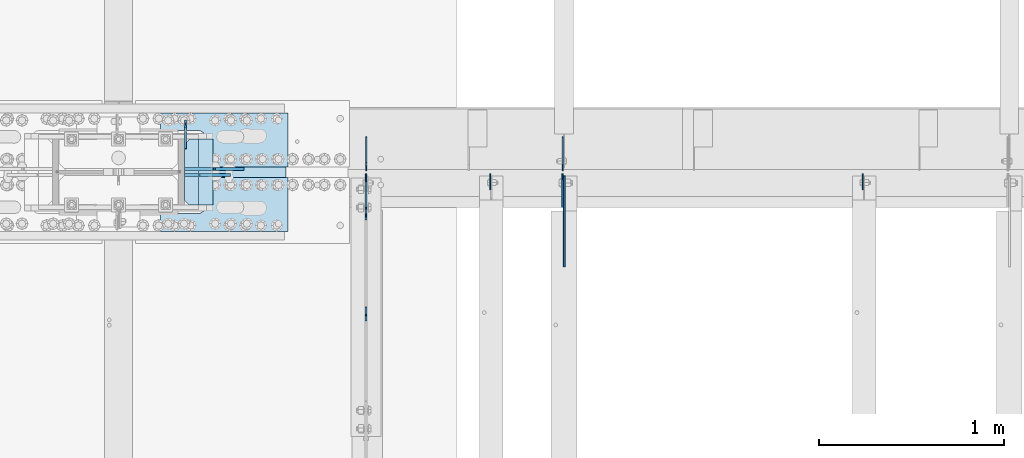
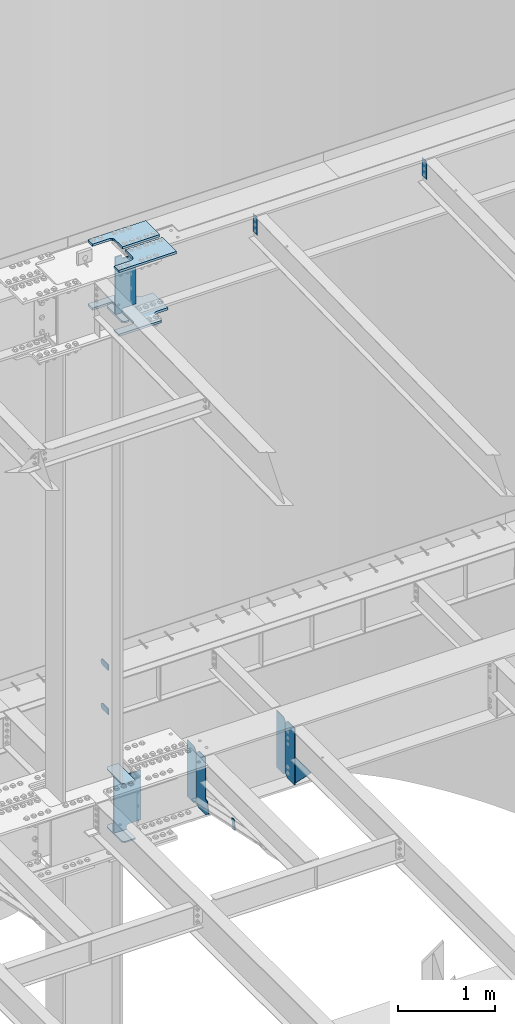
# One storey, part 1631 of 1763: 18 plates, 8 elements without a shape of their own.
"""IFC2X3 building model written with IfcOpenShell, lengths in millimetres."""

from ifc_helpers import new_model, si_unit, frame, origin_with_axes, place, context, subcontext, project, spatial, faceted_brep, material, type_object, element, aggregate, save


model = new_model("IFC2X3")

# Units and contexts
model_context = context("Model", 3, precision=1e-05, world=origin_with_axes())
body_context = subcontext(model_context, "Body", "Model", "MODEL_VIEW")
ifc_project = project(units=[si_unit("LENGTHUNIT", "METRE", prefix="MILLI"), si_unit("AREAUNIT", "SQUARE_METRE"), si_unit("VOLUMEUNIT", "CUBIC_METRE"), si_unit("MASSUNIT", "GRAM", prefix="KILO"), si_unit("TIMEUNIT", "SECOND"), si_unit("PLANEANGLEUNIT", "RADIAN"), si_unit("SOLIDANGLEUNIT", "STERADIAN"), si_unit("THERMODYNAMICTEMPERATUREUNIT", "DEGREE_CELSIUS"), si_unit("LUMINOUSINTENSITYUNIT", "LUMEN")], contexts=[model_context])

# Site, building, storey
site_placement = place(None, origin_with_axes())
site = spatial("IfcSite", under=ifc_project, at=site_placement, CompositionType="ELEMENT")
building_placement = place(site_placement, origin_with_axes())
building = spatial("IfcBuilding", under=site, at=building_placement, Name="Undefined", CompositionType="ELEMENT")
storey_placement = place(building_placement, origin_with_axes())
storey = spatial("IfcBuildingStorey", under=building, at=storey_placement, Name="Undefined", CompositionType="ELEMENT", Elevation=0.0)

# Assembly, plates
assembly_1_placement = place(storey_placement, origin_with_axes())
assembly_1 = element("IfcElementAssembly", 1, at=assembly_1_placement, inside=storey, Name="COLUMN", AssemblyPlace="NOTDEFINED", PredefinedType="RIGID_FRAME")
ifc_material_1 = material(Name="STEEL/A36")
plate_type_1 = type_object("IfcPlateType", PredefinedType="NOTDEFINED")
plate_1_placement = place(assembly_1_placement, frame((-49040.4872736983, 52247.8, 6489.69999847412), z_axis=(0.0, 0.0, -1.0), x_axis=(0.0, 1.0, 0.0)))
plate_1 = element("IfcPlate", 2, at=plate_1_placement, type_object=plate_type_1, material=ifc_material_1, Name="PLATE", context=body_context, shape_type="Brep", body=[
    faceted_brep([(0.0, -4.76249999999982, 0.0), (0.0, -4.76250000000073, 76.1999969482422), (0.0, 4.76250000000073, 76.1999969482422), (0.0, 4.76249999999982, 0.0), (114.299995422363, -4.76250000000073, 76.1999969482422), (114.299995422363, 4.76250000000073, 76.1999969482422), (126.073542436527, -4.76250000000073, 74.3352502937696), (126.073542436527, 4.76250000000073, 74.3352502937696), (136.694612637817, -4.76250000000073, 68.923544725345), (136.694612637817, 4.76250000000073, 68.923544725345), (145.123541673587, -4.76250000000073, 60.4946156895749), (145.123541673587, 4.76250000000073, 60.4946156895749), (150.535247242013, -4.76250000000073, 49.8735454882844), (150.535247242013, 4.76250000000073, 49.8735454882844), (152.399993896484, -4.76250000000073, 38.0999984741211), (152.399993896484, 4.76250000000073, 38.0999984741211), (150.535247242013, -4.76250000000073, 26.3264514599578), (150.535247242013, 4.76250000000073, 26.3264514599578), (145.123541673587, -4.76250000000073, 15.7053812586673), (145.123541673587, 4.76250000000073, 15.7053812586673), (136.694612637817, -4.76250000000073, 7.27645222289721), (136.694612637817, 4.76250000000073, 7.27645222289721), (126.073542436527, -4.76250000000073, 1.86474665447258), (126.073542436527, 4.76250000000073, 1.86474665447258), (114.299995422363, -4.76250000000073, 0.0), (114.299995422363, 4.76250000000073, 0.0)], [[[0, 1, 2, 3]], [[1, 4, 5, 2]], [[4, 6, 7, 5]], [[6, 8, 9, 7]], [[8, 10, 11, 9]], [[10, 12, 13, 11]], [[12, 14, 15, 13]], [[14, 16, 17, 15]], [[16, 18, 19, 17]], [[18, 20, 21, 19]], [[20, 22, 23, 21]], [[22, 24, 25, 23]], [[24, 0, 3, 25]], [[5, 7, 9, 11, 13, 15, 17, 19, 21, 23, 25, 3, 2]], [[24, 22, 20, 18, 16, 14, 12, 10, 8, 6, 4, 1, 0]]]),
])
plate_2_placement = place(assembly_1_placement, frame((-49040.4872736983, 52247.8, 5930.89999847412), z_axis=(0.0, 0.0, -1.0), x_axis=(0.0, 1.0, 0.0)))
plate_2 = element("IfcPlate", 3, at=plate_2_placement, type_object=plate_type_1, material=ifc_material_1, Name="PLATE", context=body_context, shape_type="Brep", body=[
    faceted_brep([(0.0, -4.76249999999982, 0.0), (0.0, -4.76250000000073, 76.1999969482422), (0.0, 4.76250000000073, 76.1999969482422), (0.0, 4.76249999999982, 0.0), (114.299995422363, -4.76250000000073, 76.1999969482422), (114.299995422363, 4.76250000000073, 76.1999969482422), (126.073542436527, -4.76250000000073, 74.3352502937696), (126.073542436527, 4.76250000000073, 74.3352502937696), (136.694612637817, -4.76250000000073, 68.923544725345), (136.694612637817, 4.76250000000073, 68.923544725345), (145.123541673587, -4.76250000000073, 60.4946156895749), (145.123541673587, 4.76250000000073, 60.4946156895749), (150.535247242013, -4.76250000000073, 49.8735454882844), (150.535247242013, 4.76250000000073, 49.8735454882844), (152.399993896484, -4.76250000000073, 38.0999984741211), (152.399993896484, 4.76250000000073, 38.0999984741211), (150.535247242013, -4.76250000000073, 26.3264514599578), (150.535247242013, 4.76250000000073, 26.3264514599578), (145.123541673587, -4.76250000000073, 15.7053812586673), (145.123541673587, 4.76250000000073, 15.7053812586673), (136.694612637817, -4.76250000000073, 7.27645222289721), (136.694612637817, 4.76250000000073, 7.27645222289721), (126.073542436527, -4.76250000000073, 1.86474665447258), (126.073542436527, 4.76250000000073, 1.86474665447258), (114.299995422363, -4.76250000000073, 0.0), (114.299995422363, 4.76250000000073, 0.0)], [[[0, 1, 2, 3]], [[1, 4, 5, 2]], [[4, 6, 7, 5]], [[6, 8, 9, 7]], [[8, 10, 11, 9]], [[10, 12, 13, 11]], [[12, 14, 15, 13]], [[14, 16, 17, 15]], [[16, 18, 19, 17]], [[18, 20, 21, 19]], [[20, 22, 23, 21]], [[22, 24, 25, 23]], [[24, 0, 3, 25]], [[5, 7, 9, 11, 13, 15, 17, 19, 21, 23, 25, 3, 2]], [[24, 22, 20, 18, 16, 14, 12, 10, 8, 6, 4, 1, 0]]]),
])

# Assembly, plate
assembly_2_placement = place(storey_placement, origin_with_axes())
assembly_2 = element("IfcElementAssembly", 4, at=assembly_2_placement, inside=storey, Name="ANGLE BRACE", AssemblyPlace="NOTDEFINED", PredefinedType="RIGID_FRAME")
plate_type_2 = type_object("IfcPlateType", PredefinedType="NOTDEFINED")
plate_3_placement = place(assembly_2_placement, frame((-48064.1747736983, 51342.4281032895, 4746.91590772782), z_axis=(0.0, -0.208168683014592, -0.978092940068566), x_axis=(0.0, 0.978092940068566, -0.208168683014588)))
plate_3 = element("IfcPlate", 5, at=plate_3_placement, type_object=plate_type_2, material=ifc_material_1, Name="PLATE", context=body_context, shape_type="Brep", body=[
    faceted_brep([(0.0, -4.76249999999982, 0.0), (2.11002770811319e-09, -4.76249999999709, 127.040328979458), (2.11002770811319e-09, 4.76249999999709, 127.040328979458), (0.0, 4.76249999999982, 0.0), (50.7119293213109, -4.76249999999709, 126.999992370584), (50.7119293213109, 4.76249999999709, 126.999992370584), (50.7119293211581, -4.76249999999709, 1.63709046319127e-11), (50.7119293211581, 4.76249999999709, 1.63709046319127e-11)], [[[0, 1, 2, 3]], [[1, 4, 5, 2]], [[4, 6, 7, 5]], [[6, 0, 3, 7]], [[5, 7, 3, 2]], [[6, 4, 1, 0]]]),
])
aggregate(assembly_2, [plate_3])

# Assembly, plates
assembly_3_placement = place(storey_placement, origin_with_axes())
assembly_3 = element("IfcElementAssembly", 6, at=assembly_3_placement, inside=storey, Name="BEAM", AssemblyPlace="NOTDEFINED", PredefinedType="RIGID_FRAME")
plate_type_3 = type_object("IfcPlateType", PredefinedType="NOTDEFINED")
plate_4_placement = place(assembly_3_placement, frame((-48062.587273746, 52128.7375, 4448.175), z_axis=(0.0, 0.0, 1.0), x_axis=(0.0, 1.0, 0.0)))
plate_4 = element("IfcPlate", 7, at=plate_4_placement, type_object=plate_type_3, material=ifc_material_1, Name="PLATE", context=body_context, shape_type="Brep", body=[
    faceted_brep([(0.0, -3.17500000000291, 44.4500000000007), (0.0, -3.17500000000291, 673.099987030029), (0.0, 3.17500000000291, 673.099987030029), (0.0, 3.17500000000291, 44.4500000000007), (44.4500007629395, -3.17500000000291, 717.549987792969), (44.4500007629395, 3.17500000000291, 717.549987792969), (182.5625, -3.17500000000291, 717.549987792969), (182.5625, 3.17500000000291, 717.549987792969), (182.5625, -3.17500000000291, 0.0), (182.5625, 3.17500000000291, 0.0), (44.4500007629395, -3.17500000000291, 0.0), (44.4500007629395, 3.17500000000291, 0.0)], [[[0, 1, 2, 3]], [[1, 4, 5, 2]], [[4, 6, 7, 5]], [[6, 8, 9, 7]], [[8, 10, 11, 9]], [[10, 0, 3, 11]], [[5, 7, 9, 11, 3, 2]], [[10, 8, 6, 4, 1, 0]]]),
])
plate_5_placement = place(assembly_3_placement, frame((-47000.0206070794, 52128.7375, 4448.175), z_axis=(0.0, 0.0, 1.0), x_axis=(0.0, 1.0, 0.0)))
plate_5 = element("IfcPlate", 8, at=plate_5_placement, type_object=plate_type_3, material=ifc_material_1, Name="PLATE", context=body_context, shape_type="Brep", body=[
    faceted_brep([(0.0, -3.17500000000291, 31.75), (0.0, -3.17500000000291, 687.387512207031), (0.0, 3.17500000000291, 687.387512207031), (0.0, 3.17500000000291, 31.75), (31.75, -3.17500000000291, 719.137512207031), (31.75, 3.17500000000291, 719.137512207031), (182.5625, -3.17500000000291, 719.137512207031), (182.5625, 3.17500000000291, 719.137512207031), (182.5625, -3.17500000000291, 0.0), (182.5625, 3.17500000000291, 0.0), (31.7499999999036, -3.17499999997381, 9.42916855706244e-11), (31.7499999998854, 3.17500000000291, 9.42916855706244e-11)], [[[0, 1, 2, 3]], [[1, 4, 5, 2]], [[4, 6, 7, 5]], [[6, 8, 9, 7]], [[8, 10, 11, 9]], [[10, 0, 3, 11]], [[5, 7, 9, 11, 3, 2]], [[10, 8, 6, 4, 1, 0]]]),
])
plate_type_4 = type_object("IfcPlateType", PredefinedType="NOTDEFINED")
plate_6_placement = place(assembly_3_placement, frame((-47000.8153570965, 52112.8625, 4448.175), z_axis=(0.0, 0.0, 1.0), x_axis=(0.0, -1.0, 0.0)))
plate_6 = element("IfcPlate", 9, at=plate_6_placement, type_object=plate_type_4, material=ifc_material_1, Name="PLATE", context=body_context, shape_type="Brep", body=[
    faceted_brep([(0.0, -3.96899999999732, 31.75), (0.0, -3.96899999999732, 687.387512207031), (0.0, 3.96899999999732, 687.387512207031), (0.0, 3.96899999999732, 31.75), (31.75, -3.96899999999732, 719.137512207031), (31.75, 3.96899999999732, 719.137512207031), (182.5625, -3.96899999999732, 719.137512207031), (182.5625, 3.96899999999732, 719.137512207031), (182.5625, -3.96899999999732, 0.0), (182.5625, 3.96899999999732, 0.0), (31.75, -3.96899999999732, 0.0), (31.75, 3.96899999999732, 0.0)], [[[0, 1, 2, 3]], [[1, 4, 5, 2]], [[4, 6, 7, 5]], [[6, 8, 9, 7]], [[8, 10, 11, 9]], [[10, 0, 3, 11]], [[5, 7, 9, 11, 3, 2]], [[10, 8, 6, 4, 1, 0]]]),
])

# Assembly, plate
assembly_4_placement = place(storey_placement, origin_with_axes())
assembly_4 = element("IfcElementAssembly", 10, at=assembly_4_placement, inside=storey, Name="BEAM", AssemblyPlace="NOTDEFINED", PredefinedType="RIGID_FRAME")
plate_type_5 = type_object("IfcPlateType", PredefinedType="NOTDEFINED")
plate_7_placement = place(assembly_4_placement, frame((-46992.0831070794, 51930.3004272461, 4794.2499684514), z_axis=(0.0, 0.0, -1.0), x_axis=(0.0, -1.0, 0.0)))
plate_7 = element("IfcPlate", 11, at=plate_7_placement, type_object=plate_type_5, material=ifc_material_1, Name="PLATE", context=body_context, shape_type="Brep", body=[
    faceted_brep([(0.0, -4.76249999999982, 0.0), (-169.862075805664, -4.76249999999709, 6.30279828328639e-10), (-169.862075805664, 4.76249999999709, 6.30279828328639e-10), (0.0, 4.76249999999982, 0.0), (-169.862091064453, -4.76249999999709, 323.002471923828), (-169.862091064453, 4.76249999999709, 323.002471923828), (6.38101482763886e-09, -4.76249999999709, 323.002471923828), (6.38101482763886e-09, 4.76249999999709, 323.002471923828), (322.262145996094, -4.76249999999709, -1.15778675535694e-09), (322.262145996094, 4.76249999999709, -1.15778675535694e-09)], [[[0, 1, 2, 3]], [[1, 4, 5, 2]], [[4, 6, 7, 5]], [[6, 8, 9, 7]], [[8, 0, 3, 9]], [[5, 7, 9, 3, 2]], [[8, 6, 4, 1, 0]]]),
])
aggregate(assembly_4, [plate_7])

# Plate
ifc_material_2 = material(Name="STEEL/A572-50")
plate_type_6 = type_object("IfcPlateType", PredefinedType="NOTDEFINED")
plate_8_placement = place(assembly_1_placement, frame((-48892.8497798019, 52298.6, 5157.7875), z_axis=(-1.0, 0.0, 0.0), x_axis=(0.0, -1.0, 0.0)))
plate_8 = element("IfcPlate", 12, at=plate_8_placement, type_object=plate_type_6, material=ifc_material_2, Name="PLATE", context=body_context, shape_type="Brep", body=[
    faceted_brep([(-7.27595761418343e-12, -7.9375, 0.0), (0.0, -7.9375, 126.999994277954), (0.0, 7.9375, 126.999994277954), (-7.27595761418343e-12, 7.9375, 0.0), (25.3999996185303, -7.9375, 152.399993896484), (25.3999996185303, 7.9375, 152.399993896484), (330.200006484985, -7.9375, 152.399993896484), (330.200006484985, 7.9375, 152.399993896484), (355.600006103516, -7.9375, 126.999994277954), (355.600006103516, 7.9375, 126.999994277954), (355.600006103516, -7.9375, 0.0), (355.600006103516, 7.9375, 0.0)], [[[0, 1, 2, 3]], [[1, 4, 5, 2]], [[4, 6, 7, 5]], [[6, 8, 9, 7]], [[8, 10, 11, 9]], [[10, 0, 3, 11]], [[5, 7, 9, 11, 3, 2]], [[10, 8, 6, 4, 1, 0]]]),
])

plate_9_placement = place(assembly_1_placement, frame((-48892.8497798019, 52298.6, 4427.5375), z_axis=(-1.0, 0.0, 0.0), x_axis=(0.0, -1.0, 0.0)))
plate_9 = element("IfcPlate", 13, at=plate_9_placement, type_object=plate_type_6, material=ifc_material_2, Name="PLATE", context=body_context, shape_type="Brep", body=[
    faceted_brep([(-7.27595761418343e-12, -7.9375, 0.0), (0.0, -7.9375, 126.999994277954), (0.0, 7.9375, 126.999994277954), (-7.27595761418343e-12, 7.9375, 0.0), (25.3999996185303, -7.9375, 152.399993896484), (25.3999996185303, 7.9375, 152.399993896484), (330.200006484985, -7.9375, 152.399993896484), (330.200006484985, 7.9375, 152.399993896484), (355.600006103516, -7.9375, 126.999994277954), (355.600006103516, 7.9375, 126.999994277954), (355.600006103516, -7.9375, 0.0), (355.600006103516, 7.9375, 0.0)], [[[0, 1, 2, 3]], [[1, 4, 5, 2]], [[4, 6, 7, 5]], [[6, 8, 9, 7]], [[8, 10, 11, 9]], [[10, 0, 3, 11]], [[5, 7, 9, 11, 3, 2]], [[10, 8, 6, 4, 1, 0]]]),
])

# Assembly, plate
assembly_5_placement = place(storey_placement, origin_with_axes())
assembly_5 = element("IfcElementAssembly", 14, at=assembly_5_placement, inside=storey, Name="PLATE", AssemblyPlace="NOTDEFINED", PredefinedType="RIGID_FRAME")
plate_type_7 = type_object("IfcPlateType", PredefinedType="NOTDEFINED")
plate_10_placement = place(assembly_5_placement, frame((-49175.4247736983, 51800.1250002128, 10955.3374917654), z_axis=(0.0, 1.0, 0.0), x_axis=(1.0, 0.0, 0.0)))
plate_10 = element("IfcPlate", 15, at=plate_10_placement, type_object=plate_type_7, material=ifc_material_2, Name="PLATE", context=body_context, shape_type="Brep", body=[
    faceted_brep([(0.0, -14.2875000000058, 0.0), (0.0, -14.2875000000004, 95.25), (0.0, 14.2875000000004, 95.25), (0.0, 14.2875000000058, 0.0), (209.550006866455, -14.2875000000004, 95.25), (209.550006866455, 14.2875000000004, 95.25), (220.342425159237, -14.2875000000004, 96.9593511310522), (220.342425159237, 14.2875000000004, 96.9593511310522), (230.078406354325, -14.2875000000004, 101.920081325748), (230.078406354325, 14.2875000000004, 101.920081325748), (237.804924777767, -14.2875000000004, 109.646599749191), (237.804924777767, 14.2875000000004, 109.646599749191), (242.765654972463, -14.2875000000004, 119.382580944279), (242.765654972463, 14.2875000000004, 119.382580944279), (244.475006103516, -14.2875000000004, 130.174999237061), (244.475006103516, 14.2875000000004, 130.174999237061), (244.475006103516, -14.2875000000004, 511.174976348877), (244.475006103516, 14.2875000000004, 511.174976348877), (242.765654972463, -14.2875000000004, 521.967394641659), (242.765654972463, 14.2875000000004, 521.967394641659), (237.804924777767, -14.2875000000004, 531.703375836747), (237.804924777767, 14.2875000000004, 531.703375836747), (230.078406354325, -14.2875000000004, 539.429894260189), (230.078406354325, 14.2875000000004, 539.429894260189), (220.342425159237, -14.2875000000004, 544.390624454885), (220.342425159237, 14.2875000000004, 544.390624454885), (209.550006866455, -14.2875000000004, 546.099975585938), (209.550006866455, 14.2875000000004, 546.099975585938), (0.0, -14.2875000000004, 546.099975585938), (0.0, 14.2875000000004, 546.099975585938), (0.0, -14.2875000000004, 641.349975585938), (0.0, 14.2875000000004, 641.349975585938), (508.0, -14.2875000000004, 641.349975585938), (508.0, 14.2875000000004, 641.349975585938), (508.0, -14.2875000000004, 511.174999237061), (508.0, 14.2875000000004, 511.174999237061), (509.709351131052, -14.2875000000004, 500.382580944279), (509.709351131052, 14.2875000000004, 500.382580944279), (514.670081325748, -14.2875000000004, 490.646599749191), (514.670081325748, 14.2875000000004, 490.646599749191), (522.396599749191, -14.2875000000004, 482.920081325748), (522.396599749191, 14.2875000000004, 482.920081325748), (532.132580944279, -14.2875000000004, 477.959351131052), (532.132580944279, 14.2875000000004, 477.959351131052), (542.924999237061, -14.2875000000004, 476.25), (542.924999237061, 14.2875000000004, 476.25), (679.450012207031, -14.2875000000004, 476.25), (679.450012207031, 14.2875000000004, 476.25), (679.450012207031, -14.2875000000004, 165.100006103516), (679.450012207031, 14.2875000000004, 165.100006103516), (542.924999237061, -14.2875000000004, 165.100006103516), (542.924999237061, 14.2875000000004, 165.100006103516), (532.132580944279, -14.2875000000004, 163.390654972463), (532.132580944279, 14.2875000000004, 163.390654972463), (522.396599749191, -14.2875000000004, 158.429924777767), (522.396599749191, 14.2875000000004, 158.429924777767), (514.670081325748, -14.2875000000004, 150.703406354325), (514.670081325748, 14.2875000000004, 150.703406354325), (509.709351131052, -14.2875000000004, 140.967425159237), (509.709351131052, 14.2875000000004, 140.967425159237), (508.0, -14.2875000000004, 130.175006866455), (508.0, 14.2875000000004, 130.175006866455), (508.0, -14.2875000000004, 0.0), (508.0, 14.2875000000004, 0.0)], [[[0, 1, 2, 3]], [[1, 4, 5, 2]], [[4, 6, 7, 5]], [[6, 8, 9, 7]], [[8, 10, 11, 9]], [[10, 12, 13, 11]], [[12, 14, 15, 13]], [[14, 16, 17, 15]], [[16, 18, 19, 17]], [[18, 20, 21, 19]], [[20, 22, 23, 21]], [[22, 24, 25, 23]], [[24, 26, 27, 25]], [[26, 28, 29, 27]], [[28, 30, 31, 29]], [[30, 32, 33, 31]], [[32, 34, 35, 33]], [[34, 36, 37, 35]], [[36, 38, 39, 37]], [[38, 40, 41, 39]], [[40, 42, 43, 41]], [[42, 44, 45, 43]], [[44, 46, 47, 45]], [[46, 48, 49, 47]], [[48, 50, 51, 49]], [[50, 52, 53, 51]], [[52, 54, 55, 53]], [[54, 56, 57, 55]], [[56, 58, 59, 57]], [[58, 60, 61, 59]], [[60, 62, 63, 61]], [[62, 0, 3, 63]], [[5, 7, 9, 11, 13, 15, 17, 19, 21, 23, 25, 27, 29, 31, 33, 35, 37, 39, 41, 43, 45, 47, 49, 51, 53, 55, 57, 59, 61, 63, 3, 2]], [[62, 60, 58, 56, 54, 52, 50, 48, 46, 44, 42, 40, 38, 36, 34, 32, 30, 28, 26, 24, 22, 20, 18, 16, 14, 12, 10, 8, 6, 4, 1, 0]]]),
])
aggregate(assembly_5, [plate_10])

assembly_6_placement = place(storey_placement, origin_with_axes())
assembly_6 = element("IfcElementAssembly", 16, at=assembly_6_placement, inside=storey, Name="TOP PLATE", AssemblyPlace="NOTDEFINED", PredefinedType="RIGID_FRAME")
plate_type_8 = type_object("IfcPlateType", PredefinedType="NOTDEFINED")
plate_11_placement = place(assembly_6_placement, frame((-48486.4497736983, 52092.2250002128, 11761.7874917654), z_axis=(0.0, -1.0, 0.0), x_axis=(-1.0, 0.0, 0.0)))
plate_11 = element("IfcPlate", 17, at=plate_11_placement, type_object=plate_type_8, material=ifc_material_2, Name="TOP PLATE", context=body_context, shape_type="Brep", body=[
    faceted_brep([(0.0, -14.2875000000058, 0.0), (0.0, -14.2875000000004, 292.100006103516), (0.0, 14.2875000000004, 292.100006103516), (0.0, 14.2875000000058, 0.0), (688.974975585938, -14.2875000000004, 292.100006103516), (688.974975585938, 14.2875000000004, 292.100006103516), (688.974975585938, -14.2875000000004, 196.850006103516), (688.974975585938, 14.2875000000004, 196.850006103516), (488.950000762939, -14.2875000000004, 196.850006103516), (488.950000762939, 14.2875000000004, 196.850006103516), (471.939721902345, -14.2875000000004, 193.466451265565), (471.939721902345, 14.2875000000004, 193.466451265565), (457.519103799721, -14.2875000000004, 183.830902303795), (457.519103799721, 14.2875000000004, 183.830902303795), (447.88355483795, -14.2875000000004, 169.410284201171), (447.88355483795, 14.2875000000004, 169.410284201171), (444.5, -14.2875000000004, 152.400005340576), (444.5, 14.2875000000004, 152.400005340576), (444.5, -14.2875000000004, 0.0), (444.5, 14.2875000000004, 0.0)], [[[0, 1, 2, 3]], [[1, 4, 5, 2]], [[4, 6, 7, 5]], [[6, 8, 9, 7]], [[8, 10, 11, 9]], [[10, 12, 13, 11]], [[12, 14, 15, 13]], [[14, 16, 17, 15]], [[16, 18, 19, 17]], [[18, 0, 3, 19]], [[5, 7, 9, 11, 13, 15, 17, 19, 3, 2]], [[18, 16, 14, 12, 10, 8, 6, 4, 1, 0]]]),
])
aggregate(assembly_6, [plate_11])

assembly_7_placement = place(storey_placement, origin_with_axes())
assembly_7 = element("IfcElementAssembly", 18, at=assembly_7_placement, inside=storey, Name="TOP PLATE", AssemblyPlace="NOTDEFINED", PredefinedType="RIGID_FRAME")
plate_12_placement = place(assembly_7_placement, frame((-48930.9497736983, 52149.3750002128, 11761.7874917654), z_axis=(0.0, 1.0, 0.0), x_axis=(1.0, 0.0, 0.0)))
plate_12 = element("IfcPlate", 19, at=plate_12_placement, type_object=plate_type_8, material=ifc_material_2, Name="TOP PLATE", context=body_context, shape_type="Brep", body=[
    faceted_brep([(0.0, -14.2875000000058, 0.0), (0.0, -14.2875000000004, 152.400001525879), (0.0, 14.2875000000004, 152.400001525879), (0.0, 14.2875000000058, 0.0), (-3.38355483795021, -14.2875000000004, 169.410284201171), (-3.38355483795021, 14.2875000000004, 169.410284201171), (-13.0191037997211, -14.2875000000004, 183.830902303795), (-13.0191037997211, 14.2875000000004, 183.830902303795), (-27.4397219023449, -14.2875000000004, 193.466451265565), (-27.4397219023449, 14.2875000000004, 193.466451265565), (-44.4500007629395, -14.2875000000004, 196.850006103516), (-44.4500007629395, 14.2875000000004, 196.850006103516), (-244.475006103516, -14.2875000000004, 196.850006103516), (-244.475006103516, 14.2875000000004, 196.850006103516), (-244.475006103516, -14.2875000000004, 292.100006103516), (-244.475006103516, 14.2875000000004, 292.100006103516), (444.5, -14.2875000000004, 292.100006103516), (444.5, 14.2875000000004, 292.100006103516), (444.5, -14.2875000000004, 0.0), (444.5, 14.2875000000004, 0.0)], [[[0, 1, 2, 3]], [[1, 4, 5, 2]], [[4, 6, 7, 5]], [[6, 8, 9, 7]], [[8, 10, 11, 9]], [[10, 12, 13, 11]], [[12, 14, 15, 13]], [[14, 16, 17, 15]], [[16, 18, 19, 17]], [[18, 0, 3, 19]], [[5, 7, 9, 11, 13, 15, 17, 19, 3, 2]], [[18, 16, 14, 12, 10, 8, 6, 4, 1, 0]]]),
])
aggregate(assembly_7, [plate_12])

# Plate
plate_type_9 = type_object("IfcPlateType", PredefinedType="NOTDEFINED")
plate_13_placement = place(assembly_1_placement, frame((-49045.2497736983, 52298.6, 10980.7374917654), z_axis=(1.0, 0.0, 0.0), x_axis=(0.0, -1.0, 0.0)))
plate_13 = element("IfcPlate", 20, at=plate_13_placement, type_object=plate_type_9, material=ifc_material_2, Name="BRIDGE PLATE", context=body_context, shape_type="Brep", body=[
    faceted_brep([(0.0, -11.1124999999993, 25.3999996185303), (0.0, -11.1124999999993, 76.1999969482422), (0.0, 11.1124999999993, 76.1999969482422), (0.0, 11.1124999999993, 25.3999996185303), (355.600006103516, -11.1124999999993, 76.1999969482422), (355.600006103516, 11.1124999999993, 76.1999969482422), (355.600006103516, -11.1124999999993, 25.3999996185303), (355.600006103516, 11.1124999999993, 25.3999996185303), (330.200006484985, -11.1124999999993, 0.0), (330.200006484985, 11.1124999999993, 0.0), (25.3999996185303, -11.1124999999993, 0.0), (25.3999996185303, 11.1124999999993, 0.0)], [[[0, 1, 2, 3]], [[1, 4, 5, 2]], [[4, 6, 7, 5]], [[6, 8, 9, 7]], [[8, 10, 11, 9]], [[10, 0, 3, 11]], [[5, 7, 9, 11, 3, 2]], [[10, 8, 6, 4, 1, 0]]]),
])

plate_type_10 = type_object("IfcPlateType", PredefinedType="NOTDEFINED")
plate_14_placement = place(assembly_1_placement, frame((-48797.5997736983, 52104.9250002128, 11045.8249917654), z_axis=(-1.0, 0.0, 0.0), x_axis=(0.0, 0.0, 1.0)))
plate_14 = element("IfcPlate", 21, at=plate_14_placement, type_object=plate_type_10, material=ifc_material_2, Name="SHEAR TAB", context=body_context, shape_type="Brep", body=[
    faceted_brep([(-7.27595761418343e-12, -7.9375, 0.0), (0.0, -7.9375, 158.749997138977), (0.0, 7.9375, 158.749997138977), (-7.27595761418343e-12, 7.9375, 0.0), (-0.966729922587547, -7.9375, 163.610076657023), (-0.966729922587547, 7.9375, 163.610076657023), (-3.71974382306507, -7.9375, 167.730253125177), (-3.71974382306507, 7.9375, 167.730253125177), (-7.83992029121873, -7.9375, 170.483267025651), (-7.83992029121873, 7.9375, 170.483267025651), (-12.6999998092651, -7.9375, 171.449996948242), (-12.6999998092651, 7.9375, 171.449996948242), (-53.9749984741211, -7.9375, 171.449996948242), (-53.9749984741211, 7.9375, 171.449996948242), (-53.9749984741211, -7.9375, 247.649993896484), (-53.9749984741211, 7.9375, 247.649993896484), (671.512451171875, -7.9375, 247.649993896484), (671.512451171875, 7.9375, 247.649993896484), (671.512451171875, -7.9375, 171.449996948242), (671.512451171875, 7.9375, 171.449996948242), (638.174975395203, -7.9375, 171.449996948242), (638.174975395203, 7.9375, 171.449996948242), (633.314895877156, -7.9375, 170.483267025651), (633.314895877156, 7.9375, 170.483267025651), (629.194719409003, -7.9375, 167.730253125177), (629.194719409003, 7.9375, 167.730253125177), (626.441705508525, -7.9375, 163.610076657023), (626.441705508525, 7.9375, 163.610076657023), (625.474975585938, -7.9375, 158.749997138977), (625.474975585938, 7.9375, 158.749997138977), (625.474975585938, -7.9375, 0.0), (625.474975585938, 7.9375, 0.0)], [[[0, 1, 2, 3]], [[1, 4, 5, 2]], [[4, 6, 7, 5]], [[6, 8, 9, 7]], [[8, 10, 11, 9]], [[10, 12, 13, 11]], [[12, 14, 15, 13]], [[14, 16, 17, 15]], [[16, 18, 19, 17]], [[18, 20, 21, 19]], [[20, 22, 23, 21]], [[22, 24, 25, 23]], [[24, 26, 27, 25]], [[26, 28, 29, 27]], [[28, 30, 31, 29]], [[30, 0, 3, 31]], [[5, 7, 9, 11, 13, 15, 17, 19, 21, 23, 25, 27, 29, 31, 3, 2]], [[30, 28, 26, 24, 22, 20, 18, 16, 14, 12, 10, 8, 6, 4, 1, 0]]]),
])

plate_type_11 = type_object("IfcPlateType", PredefinedType="NOTDEFINED")
plate_15_placement = place(assembly_1_placement, frame((-48724.5747736984, 52136.675, 4435.475), z_axis=(-1.0, 0.0, 0.0), x_axis=(0.0, 0.0, 1.0)))
plate_15 = element("IfcPlate", 22, at=plate_15_placement, type_object=plate_type_11, material=ifc_material_2, Name="SHEAR TAB", context=body_context, shape_type="Brep", body=[
    faceted_brep([(684.212475585938, -7.9375, 0.0), (684.212475585938, 7.9375, 0.0), (684.212475585938, 7.9375, 142.875009536743), (684.212475585938, -7.9375, 142.875009536743), (686.145935431114, 7.9375, 152.595168572821), (686.145935431114, -7.9375, 152.595168572821), (691.65196323207, 7.9375, 160.835521509129), (691.65196323207, -7.9375, 160.835521509129), (699.892316168377, 7.9375, 166.341549310091), (699.892316168377, -7.9375, 166.341549310091), (709.612475204468, 7.9375, 168.275009155273), (709.612475204468, -7.9375, 168.275009155273), (712.787475585938, -7.9375, 168.275009155273), (712.787475585938, 7.9375, 168.275009155273), (58.7375022888209, -7.9375, 142.875012588498), (58.7375022888209, 7.9375, 142.875012588498), (58.7375022888209, 7.9375, 0.0), (58.7375022888209, -7.9375, 0.0), (56.8040424436449, -7.9375, 152.595171624591), (56.8040424436449, 7.9375, 152.595171624591), (51.2980146426889, -7.9375, 160.835524560898), (51.2980146426889, 7.9375, 160.835524560898), (43.0576617063816, -7.9375, 166.341552361846), (43.0576617063816, 7.9375, 166.341552361846), (33.3375026702906, -7.9375, 168.275012207028), (33.3375026702906, 7.9375, 168.275012207028), (0.0, -7.9375, 168.275012207028), (0.0, 7.9375, 168.275012207028), (0.0, -7.9375, 320.674987792969), (0.0, 7.9375, 320.674987792969), (712.787475585938, -7.9375, 320.674987792969), (712.787475585938, 7.9375, 320.674987792969)], [[[0, 1, 2, 3]], [[3, 2, 4, 5]], [[5, 4, 6, 7]], [[7, 6, 8, 9]], [[9, 8, 10, 11]], [[12, 11, 10, 13]], [[14, 15, 16, 17]], [[18, 19, 15, 14]], [[20, 21, 19, 18]], [[22, 23, 21, 20]], [[24, 25, 23, 22]], [[26, 27, 25, 24]], [[28, 29, 27, 26]], [[28, 30, 31, 29]], [[31, 30, 12, 13]], [[8, 6, 4, 2, 1, 16, 15, 19, 21, 23, 25, 27, 29, 31, 13, 10]], [[17, 16, 1, 0]], [[30, 28, 26, 24, 22, 20, 18, 14, 17, 0, 3, 5, 7, 9, 11, 12]]]),
])

aggregate(assembly_1, [plate_1, plate_2, plate_8, plate_9, plate_14, plate_13, plate_15])

plate_type_12 = type_object("IfcPlateType", PredefinedType="NOTDEFINED")
plate_16_placement = place(assembly_3_placement, frame((-48064.174773746, 52112.8625, 4448.175), z_axis=(0.0, 0.0, 1.0), x_axis=(0.0, -1.0, 0.0)))
plate_16 = element("IfcPlate", 23, at=plate_16_placement, type_object=plate_type_12, material=ifc_material_1, Name="PLATE", context=body_context, shape_type="Brep", body=[
    faceted_brep([(-8.03411239758134e-08, -4.76249999999709, 44.4500007629395), (-1.21945049613714e-06, -4.76249999999709, 674.687450408936), (-1.21945049613714e-06, 4.76249999999709, 674.687450408936), (-8.03411239758134e-08, 4.76249999999709, 44.4500007629395), (44.4499994631478, -4.76249999999709, 719.137436311141), (44.4499994631478, 4.76249999999709, 719.137436311141), (182.5625, -4.76249999999709, 719.137390136719), (182.5625, 4.76249999999709, 719.137390136719), (182.5625, -4.76249999999709, 201.622897148132), (182.5625, 4.76249999999709, 201.622897148132), (183.529229922591, -4.76249999999709, 196.762817630087), (183.529229922591, 4.76249999999709, 196.762817630087), (186.282243823065, -4.76249999999709, 192.642641161933), (186.282243823065, 4.76249999999709, 192.642641161933), (190.402420291219, -4.76249999999709, 189.889627261455), (190.402420291219, 4.76249999999709, 189.889627261455), (195.262499809265, -4.76249999999709, 188.922897338867), (195.262499809265, 4.76249999999709, 188.922897338867), (219.799514770508, -4.76249999999709, 188.922897338867), (219.799514770508, 4.76249999999709, 188.922897338867), (250.737014770508, -4.76249999999709, 42.4546127319336), (250.737014770508, 4.76249999999709, 42.4546127319336), (182.5625, -4.76249999999709, -3.63797880709171e-12), (182.5625, 4.76249999999709, -3.63797880709171e-12), (44.4500007629395, -4.76249999999709, 0.0), (44.4500007629395, 4.76249999999709, 0.0)], [[[0, 1, 2, 3]], [[1, 4, 5, 2]], [[4, 6, 7, 5]], [[6, 8, 9, 7]], [[8, 10, 11, 9]], [[10, 12, 13, 11]], [[12, 14, 15, 13]], [[14, 16, 17, 15]], [[16, 18, 19, 17]], [[18, 20, 21, 19]], [[20, 22, 23, 21]], [[22, 24, 25, 23]], [[24, 0, 3, 25]], [[5, 7, 9, 11, 13, 15, 17, 19, 21, 23, 25, 3, 2]], [[24, 22, 20, 18, 16, 14, 12, 10, 8, 6, 4, 1, 0]]]),
])

aggregate(assembly_3, [plate_4, plate_16, plate_5, plate_6])

# Assembly, plates
assembly_8_placement = place(storey_placement, origin_with_axes())
assembly_8 = element("IfcElementAssembly", 24, at=assembly_8_placement, inside=storey, Name="BEAM", AssemblyPlace="NOTDEFINED", PredefinedType="RIGID_FRAME")
plate_type_13 = type_object("IfcPlateType", PredefinedType="NOTDEFINED")
plate_17_placement = place(assembly_8_placement, frame((-47392.6562102347, 52112.8625002128, 11684.3836745178), z_axis=(0.0, -1.0, 0.0), x_axis=(0.0, 0.0, -1.0)))
plate_17 = element("IfcPlate", 25, at=plate_17_placement, type_object=plate_type_13, material=ifc_material_1, Name="PLATE", context=body_context, shape_type="Brep", body=[
    faceted_brep([(1.81898940354586e-12, -3.17500000000291, 0.0), (0.0, -3.17500000000291, 87.3125), (0.0, 3.17500000000291, 87.3125), (-1.81898940354586e-12, 3.17499999997381, 0.0), (228.600006103516, -3.17500000000291, 87.3125), (228.600006103516, 3.17500000000291, 87.3125), (228.600006103516, -3.17500000001019, -7.27595761418343e-12), (228.600006103516, 3.17499999999563, -7.27595761418343e-12)], [[[0, 1, 2, 3]], [[1, 4, 5, 2]], [[4, 6, 7, 5]], [[6, 0, 3, 7]], [[5, 7, 3, 2]], [[6, 4, 1, 0]]]),
])
plate_18_placement = place(assembly_8_placement, frame((-45376.5251467711, 52112.8625002128, 11684.3836745178), z_axis=(0.0, -1.0, 0.0), x_axis=(0.0, 0.0, -1.0)))
plate_18 = element("IfcPlate", 26, at=plate_18_placement, type_object=plate_type_13, material=ifc_material_1, Name="PLATE", context=body_context, shape_type="Brep", body=[
    faceted_brep([(1.81898940354586e-12, -3.17500000000291, 0.0), (0.0, -3.17500000000291, 87.3125), (0.0, 3.17500000000291, 87.3125), (-1.81898940354586e-12, 3.17499999997381, 0.0), (228.600006103516, -3.17500000000291, 87.3125), (228.600006103516, 3.17500000000291, 87.3125), (228.600006103516, -3.17500000001019, -7.27595761418343e-12), (228.600006103516, 3.17499999999563, -7.27595761418343e-12)], [[[0, 1, 2, 3]], [[1, 4, 5, 2]], [[4, 6, 7, 5]], [[6, 0, 3, 7]], [[5, 7, 3, 2]], [[6, 4, 1, 0]]]),
])
aggregate(assembly_8, [plate_17, plate_18])

save(model, "model.ifc")
